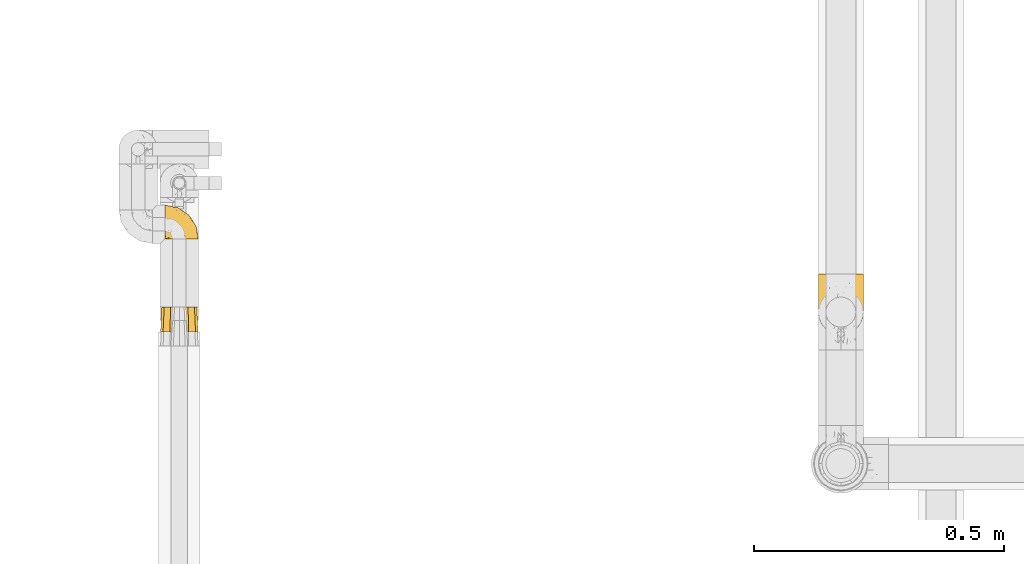
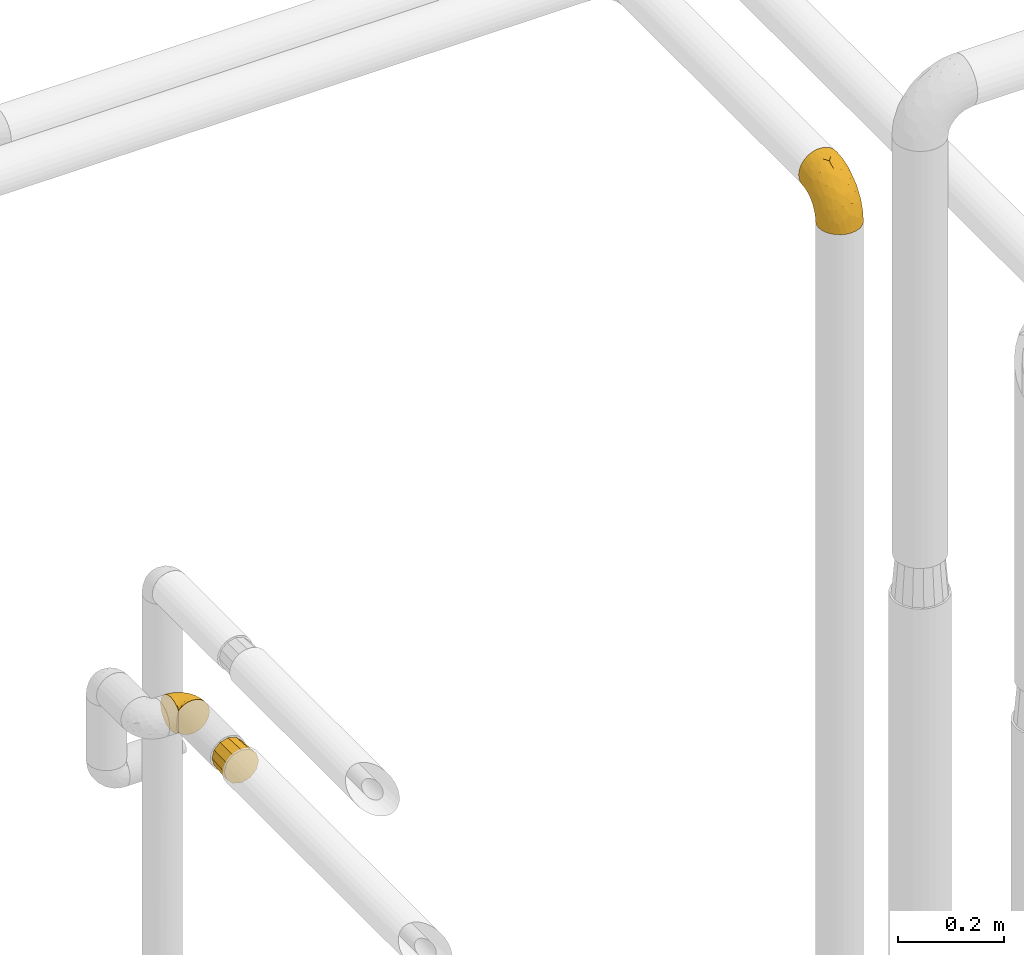
# One storey, part 111 of 827: 3 coverings.
"""IFC2X3 building model written with IfcOpenShell, lengths in millimetres."""

from ifc_helpers import new_model, entity, si_unit, converted_unit, derived_unit, direction, frame, origin, place, context, subcontext, project, spatial, faceted_brep, element, save


model = new_model("IFC2X3")

# Units and contexts
model_context = context("Model", 3, precision=0.01, world=origin(), true_north=direction((6.12303176911189e-17, 1.0)))
body_context = subcontext(model_context, "Body", "Model", "MODEL_VIEW")
ifc_project = project(units=[si_unit("LENGTHUNIT", "METRE", prefix="MILLI"), si_unit("AREAUNIT", "SQUARE_METRE"), si_unit("VOLUMEUNIT", "CUBIC_METRE"), converted_unit("PLANEANGLEUNIT", "DEGREE", entity("IfcRatioMeasure", 0.0174532925199433), si_unit("PLANEANGLEUNIT", "RADIAN"), dimensions=[0, 0, 0, 0, 0, 0, 0]), si_unit("MASSUNIT", "GRAM", prefix="KILO"), derived_unit("MASSDENSITYUNIT", [(si_unit("MASSUNIT", "GRAM", prefix="KILO"), 1), (si_unit("LENGTHUNIT", "METRE"), -3)]), derived_unit("MOMENTOFINERTIAUNIT", [(si_unit("LENGTHUNIT", "METRE"), 4)]), si_unit("TIMEUNIT", "SECOND"), si_unit("FREQUENCYUNIT", "HERTZ"), si_unit("THERMODYNAMICTEMPERATUREUNIT", "DEGREE_CELSIUS"), derived_unit("THERMALTRANSMITTANCEUNIT", [(si_unit("MASSUNIT", "GRAM", prefix="KILO"), 1), (si_unit("THERMODYNAMICTEMPERATUREUNIT", "KELVIN"), -1), (si_unit("TIMEUNIT", "SECOND"), -3)]), derived_unit("VOLUMETRICFLOWRATEUNIT", [(si_unit("LENGTHUNIT", "METRE"), 3), (si_unit("TIMEUNIT", "SECOND"), -1)]), derived_unit("MASSFLOWRATEUNIT", [(si_unit("MASSUNIT", "GRAM", prefix="KILO"), 1), (si_unit("TIMEUNIT", "SECOND"), -1)]), derived_unit("ROTATIONALFREQUENCYUNIT", [(si_unit("TIMEUNIT", "SECOND"), -1)]), si_unit("ELECTRICCURRENTUNIT", "AMPERE"), si_unit("ELECTRICVOLTAGEUNIT", "VOLT"), si_unit("POWERUNIT", "WATT"), si_unit("FORCEUNIT", "NEWTON", prefix="KILO"), si_unit("ILLUMINANCEUNIT", "LUX"), si_unit("LUMINOUSFLUXUNIT", "LUMEN"), si_unit("LUMINOUSINTENSITYUNIT", "CANDELA"), derived_unit("USERDEFINED", [(si_unit("MASSUNIT", "GRAM", prefix="KILO"), -1), (si_unit("LENGTHUNIT", "METRE"), -2), (si_unit("TIMEUNIT", "SECOND"), 3), (si_unit("LUMINOUSFLUXUNIT", "LUMEN"), 1)]), derived_unit("LINEARVELOCITYUNIT", [(si_unit("LENGTHUNIT", "METRE"), 1), (si_unit("TIMEUNIT", "SECOND"), -1)]), si_unit("PRESSUREUNIT", "PASCAL"), derived_unit("USERDEFINED", [(si_unit("LENGTHUNIT", "METRE"), -2), (si_unit("MASSUNIT", "GRAM", prefix="KILO"), 1), (si_unit("TIMEUNIT", "SECOND"), -2)]), derived_unit("LINEARFORCEUNIT", [(si_unit("MASSUNIT", "GRAM", prefix="KILO"), 1), (si_unit("LENGTHUNIT", "METRE"), 1), (si_unit("TIMEUNIT", "SECOND"), -2), (si_unit("LENGTHUNIT", "METRE"), -1)]), derived_unit("PLANARFORCEUNIT", [(si_unit("MASSUNIT", "GRAM", prefix="KILO"), 1), (si_unit("LENGTHUNIT", "METRE"), 1), (si_unit("TIMEUNIT", "SECOND"), -2), (si_unit("LENGTHUNIT", "METRE"), -2)])], contexts=[model_context])

# Site, building, storey
site_placement = place(None, origin())
site = spatial("IfcSite", under=ifc_project, at=site_placement, CompositionType="ELEMENT")
building_placement = place(site_placement, origin())
building = spatial("IfcBuilding", under=site, at=building_placement, CompositionType="ELEMENT")
storey_placement = place(building_placement, frame((0.0, 0.0, 28200.0)))
storey = spatial("IfcBuildingStorey", under=building, at=storey_placement, Name="08", CompositionType="ELEMENT", Elevation=28200.0)

# Coverings
covering_1_placement = place(storey_placement, frame((19745.57, 11707.86, 1518.12)))
element("IfcCovering", 1, at=covering_1_placement, inside=storey, Name=":ADSK_", ObjectType=":ADSK_", PredefinedType="INSULATION", context=body_context, shape_type="Brep", body=[
    faceted_brep([(1.6, 47.38, 74.68), (1.6, 54.67, 70.1), (1.6, 60.76, 64.01), (1.6, 65.34, 56.72), (1.6, 68.18, 48.6), (1.6, 69.15, 40.05), (1.6, 68.18, 31.49), (1.6, 65.33, 23.36), (1.6, 60.75, 16.07), (1.6, 54.66, 9.98), (1.6, 47.37, 5.4), (1.6, 39.25, 2.56), (1.6, 30.7, 1.6), (1.6, 22.59, 2.46), (1.6, 14.86, 5.01), (1.6, 7.84, 9.13), (1.6, 1.85, 14.62), (1.6, 1.85, 16.82), (1.6, 1.85, 18.56), (1.6, 1.85, 20.52), (1.6, 1.85, 22.49), (1.6, 1.85, 24.46), (1.6, 1.85, 26.42), (1.6, 1.85, 28.39), (1.6, 1.85, 30.36), (1.6, 1.85, 32.55), (1.6, 1.85, 34.75), (1.6, 1.85, 36.94), (1.6, 1.85, 39.13), (1.6, 1.85, 41.33), (1.6, 1.85, 43.52), (1.6, 1.85, 45.72), (1.6, 1.85, 47.91), (1.6, 1.85, 50.11), (1.6, 1.85, 52.3), (1.6, 1.85, 54.49), (1.6, 1.85, 56.69), (1.6, 1.85, 58.88), (1.6, 1.85, 61.08), (1.6, 1.85, 63.27), (1.6, 1.85, 65.47), (1.6, 7.85, 70.97), (1.6, 14.88, 75.09), (1.6, 22.61, 77.64), (1.6, 30.7, 78.5), (1.6, 39.26, 77.53), (1.85, 1.6, 14.62), (7.85, 1.6, 9.12), (14.87, 1.6, 5.0), (22.6, 1.6, 2.46), (30.7, 1.6, 1.6), (40.65, 1.6, 2.91), (49.92, 1.6, 6.75), (57.88, 1.6, 12.86), (63.99, 1.6, 20.82), (67.84, 1.6, 30.09), (69.15, 1.6, 40.05), (67.84, 1.6, 50.0), (63.99, 1.6, 59.27), (57.88, 1.6, 67.23), (49.92, 1.6, 73.34), (40.65, 1.6, 77.19), (30.7, 1.6, 78.5), (22.6, 1.6, 77.63), (14.87, 1.6, 75.09), (7.85, 1.6, 70.97), (1.85, 1.6, 65.47), (1.85, 1.6, 63.27), (1.85, 1.6, 62.29), (1.85, 1.6, 60.7), (1.85, 1.6, 59.11), (1.85, 1.6, 57.52), (1.85, 1.6, 55.93), (1.85, 1.6, 54.34), (1.85, 1.6, 52.76), (1.85, 1.6, 51.17), (1.85, 1.6, 49.58), (1.85, 1.6, 47.99), (1.85, 1.6, 46.4), (1.85, 1.6, 44.81), (1.85, 1.6, 43.22), (1.85, 1.6, 41.63), (1.85, 1.6, 40.05), (1.85, 1.6, 38.46), (1.85, 1.6, 36.87), (1.85, 1.6, 35.28), (1.85, 1.6, 33.69), (1.85, 1.6, 32.1), (1.85, 1.6, 30.51), (1.85, 1.6, 28.92), (1.85, 1.6, 27.33), (1.85, 1.6, 25.37), (1.85, 1.6, 23.4), (1.85, 1.6, 21.21), (1.85, 1.6, 19.01), (1.85, 1.6, 16.82), (1.77, 1.78, 42.32), (1.78, 1.77, 44.02), (1.77, 1.78, 47.13), (1.77, 1.77, 48.74), (1.76, 1.79, 23.57), (1.77, 1.78, 25.13), (1.79, 1.76, 61.34), (1.78, 1.77, 22.02), (1.78, 1.77, 29.72), (1.78, 1.76, 56.73), (1.78, 1.77, 55.14), (1.78, 1.77, 37.66), (1.74, 1.8, 64.12), (1.78, 1.76, 28.13), (1.78, 1.77, 26.62), (1.77, 1.78, 31.46), (1.78, 1.77, 16.16), (1.78, 1.77, 39.16), (1.78, 1.76, 50.37), (1.77, 1.77, 17.69), (1.77, 1.78, 19.17), (1.77, 1.77, 62.78), (1.78, 1.77, 58.35), (1.78, 1.77, 45.53), (1.77, 1.78, 59.91), (1.77, 1.77, 65.47), (1.72, 1.8, 65.47), (1.66, 1.82, 65.47), (1.77, 1.77, 14.62), (1.8, 1.72, 14.62), (1.82, 1.66, 14.62), (1.79, 1.76, 20.59), (1.78, 1.77, 32.99), (1.79, 1.76, 34.48), (1.78, 1.77, 51.91), (1.82, 1.66, 65.47), (1.8, 1.72, 65.47), (1.76, 1.78, 53.48), (1.66, 1.82, 14.62), (1.72, 1.8, 14.62), (1.78, 1.77, 40.77), (1.77, 1.78, 35.97), (9.41, 3.72, 7.84), (17.65, 7.41, 3.53), (7.41, 6.13, 8.32), (15.21, 19.34, 2.19), (7.41, 17.64, 3.53), (16.15, 26.8, 1.6), (28.75, 8.87, 1.6), (13.67, 9.2, 4.57), (12.79, 12.79, 3.96), (19.18, 14.62, 2.28), (29.16, 7.34, 1.6), (9.04, 5.33, 7.69), (5.74, 7.7, 8.32), (3.72, 9.41, 7.84), (8.87, 28.75, 1.6), (21.47, 21.47, 1.6), (26.8, 16.15, 1.6), (9.53, 14.14, 4.34), (7.34, 29.16, 1.6), (37.63, 57.02, 29.63), (17.92, 64.92, 27.34), (27.45, 64.0, 40.05), (37.01, 11.92, 2.39), (34.22, 19.16, 2.43), (45.87, 28.65, 9.07), (56.57, 24.62, 16.64), (52.31, 15.19, 9.54), (42.07, 18.36, 4.52), (44.74, 9.2, 4.52), (21.49, 46.98, 7.49), (11.02, 50.24, 7.49), (15.64, 56.1, 12.85), (26.02, 28.97, 2.35), (36.59, 54.46, 22.66), (65.49, 21.34, 32.9), (63.99, 18.4, 25.33), (15.2, 66.44, 40.05), (60.27, 12.07, 16.64), (45.25, 45.49, 19.99), (35.21, 50.57, 16.37), (22.52, 36.04, 3.26), (12.03, 42.07, 3.75), (13.32, 62.12, 19.58), (35.9, 37.37, 7.5), (33.87, 29.39, 4.04), (25.73, 53.59, 13.94), (26.34, 58.06, 19.58), (46.78, 49.27, 28.21), (59.54, 29.63, 24.75), (60.18, 33.21, 31.42), (53.93, 40.1, 26.2), (53.36, 44.08, 33.36), (49.36, 49.36, 40.05), (38.4, 56.68, 40.05), (66.44, 15.2, 40.05), (50.09, 35.57, 16.14), (41.08, 41.7, 12.85), (31.14, 46.4, 10.47), (28.19, 41.41, 6.49), (64.0, 27.45, 40.05), (56.68, 38.4, 40.05), (43.9, 12.99, 75.57), (65.46, 21.33, 47.37), (52.22, 42.89, 52.91), (37.61, 57.04, 50.46), (15.64, 56.11, 67.23), (13.31, 62.13, 60.5), (50.02, 21.89, 70.55), (59.28, 16.62, 63.45), (53.05, 32.9, 62.61), (21.48, 46.99, 72.6), (11.01, 50.25, 72.6), (12.03, 42.08, 76.34), (41.02, 49.91, 59.34), (35.39, 15.6, 77.76), (26.8, 16.15, 78.5), (28.75, 8.87, 78.5), (7.34, 29.16, 78.5), (65.81, 13.16, 53.16), (53.28, 10.83, 70.55), (59.8, 33.8, 48.88), (61.82, 25.02, 54.76), (17.91, 64.92, 52.74), (41.4, 32.83, 71.93), (40.48, 20.56, 75.79), (26.34, 58.07, 60.5), (31.68, 21.46, 77.86), (27.68, 28.1, 77.64), (16.15, 26.8, 78.5), (21.47, 21.47, 78.5), (28.05, 51.29, 67.23), (22.54, 36.04, 76.82), (8.87, 28.75, 78.5), (37.3, 8.45, 77.8), (41.07, 41.73, 67.23), (32.24, 39.27, 73.2), (47.4, 33.56, 67.66), (35.77, 27.29, 75.99), (17.65, 7.41, 76.57), (11.06, 3.51, 73.21), (8.55, 4.68, 71.93), (6.63, 5.52, 71.07), (12.77, 8.75, 75.09), (12.79, 12.79, 76.13), (7.41, 17.65, 76.57), (18.97, 13.9, 77.69), (3.72, 9.42, 72.26), (5.76, 7.68, 71.77), (15.21, 19.33, 77.9), (9.52, 14.13, 75.75)], [[[0, 1, 2, 3, 4, 5, 6, 7, 8, 9, 10, 11, 12, 13, 14, 15, 16, 17, 18, 19, 20, 21, 22, 23, 24, 25, 26, 27, 28, 29, 30, 31, 32, 33, 34, 35, 36, 37, 38, 39, 40, 41, 42, 43, 44, 45]], [[46, 47, 48, 49, 50, 51, 52, 53, 54, 55, 56, 57, 58, 59, 60, 61, 62, 63, 64, 65, 66, 67, 68, 69, 70, 71, 72, 73, 74, 75, 76, 77, 78, 79, 80, 81, 82, 83, 84, 85, 86, 87, 88, 89, 90, 91, 92, 93, 94, 95]], [[96, 97, 30]], [[98, 77, 99]], [[100, 101, 21]], [[69, 68, 102]], [[20, 19, 103]], [[24, 23, 104]], [[20, 103, 100]], [[72, 105, 106]], [[84, 83, 107]], [[89, 88, 104]], [[108, 67, 66]], [[109, 110, 90]], [[111, 25, 24]], [[112, 17, 16]], [[82, 113, 83]], [[109, 23, 22]], [[114, 76, 75]], [[105, 36, 106]], [[104, 111, 24]], [[18, 115, 116]], [[97, 96, 80]], [[67, 108, 117]], [[105, 71, 118]], [[31, 97, 119]], [[102, 120, 69]], [[108, 121, 122, 123, 40]], [[112, 95, 115]], [[17, 115, 18]], [[94, 116, 115]], [[117, 68, 67]], [[38, 117, 39]], [[112, 124, 125, 126, 46]], [[17, 112, 115]], [[70, 120, 118]], [[39, 117, 108]], [[120, 38, 37]], [[120, 37, 118]], [[120, 70, 69]], [[116, 94, 127]], [[128, 86, 129]], [[117, 38, 102]], [[74, 130, 75]], [[99, 33, 32]], [[115, 95, 94]], [[39, 108, 40]], [[108, 66, 131, 132, 121]], [[105, 72, 71]], [[118, 37, 36]], [[71, 70, 118]], [[35, 106, 36]], [[36, 105, 118]], [[35, 133, 106]], [[74, 73, 133]], [[106, 133, 73]], [[99, 114, 33]], [[133, 35, 34]], [[73, 72, 106]], [[95, 112, 46]], [[112, 16, 134, 135, 124]], [[130, 114, 75]], [[99, 76, 114]], [[114, 130, 33]], [[34, 33, 130]], [[78, 77, 98]], [[98, 119, 78]], [[130, 133, 34]], [[133, 130, 74]], [[79, 97, 80]], [[98, 99, 32]], [[98, 32, 31]], [[77, 76, 99]], [[97, 79, 119]], [[136, 96, 29]], [[30, 97, 31]], [[136, 29, 28]], [[81, 80, 96]], [[29, 96, 30]], [[31, 119, 98]], [[119, 79, 78]], [[96, 136, 81]], [[82, 81, 136]], [[113, 107, 83]], [[84, 107, 137]], [[107, 27, 137]], [[113, 28, 107]], [[27, 107, 28]], [[85, 84, 137]], [[137, 27, 26]], [[113, 136, 28]], [[136, 113, 82]], [[109, 89, 104]], [[86, 85, 129]], [[89, 109, 90]], [[111, 87, 128]], [[26, 129, 137]], [[88, 111, 104]], [[25, 111, 128]], [[22, 110, 109]], [[23, 109, 104]], [[110, 91, 90]], [[100, 92, 101]], [[110, 22, 101]], [[91, 110, 101]], [[116, 19, 18]], [[111, 88, 87]], [[127, 103, 19]], [[25, 128, 26]], [[86, 128, 87]], [[128, 129, 26]], [[137, 129, 85]], [[120, 102, 38]], [[117, 102, 68]], [[91, 101, 92]], [[21, 101, 22]], [[93, 92, 103]], [[100, 21, 20]], [[100, 103, 92]], [[127, 93, 103]], [[93, 127, 94]], [[116, 127, 19]], [[126, 138, 47]], [[48, 138, 139]], [[140, 125, 124]], [[141, 142, 143]], [[144, 49, 139]], [[145, 140, 146]], [[48, 139, 49]], [[139, 145, 147]], [[49, 144, 148, 50]], [[126, 125, 149]], [[14, 13, 142]], [[150, 146, 140]], [[149, 140, 145]], [[151, 150, 135]], [[151, 14, 142]], [[16, 15, 134]], [[13, 152, 142]], [[124, 150, 140]], [[141, 143, 153]], [[14, 151, 15]], [[15, 151, 134]], [[47, 46, 126]], [[139, 154, 144]], [[138, 48, 47]], [[125, 140, 149]], [[135, 134, 151]], [[146, 155, 141]], [[145, 146, 147]], [[149, 139, 138]], [[147, 153, 154]], [[147, 146, 141]], [[139, 147, 154]], [[139, 149, 145]], [[149, 138, 126]], [[147, 141, 153]], [[146, 150, 155]], [[151, 155, 150]], [[142, 141, 155]], [[13, 12, 156, 152]], [[152, 143, 142]], [[151, 142, 155]], [[150, 124, 135]], [[157, 158, 159]], [[160, 154, 161]], [[162, 163, 164]], [[165, 166, 160]], [[167, 168, 169]], [[153, 170, 161]], [[156, 12, 11]], [[158, 157, 171]], [[172, 55, 173]], [[158, 6, 174]], [[175, 54, 53]], [[52, 166, 164]], [[52, 164, 53]], [[54, 175, 173]], [[166, 52, 51]], [[176, 177, 171]], [[178, 143, 179]], [[156, 11, 179]], [[8, 7, 180]], [[169, 9, 8]], [[179, 143, 152, 156]], [[179, 11, 10]], [[168, 179, 10]], [[181, 162, 182]], [[179, 167, 178]], [[183, 184, 177]], [[183, 169, 184]], [[176, 171, 185]], [[172, 186, 187]], [[158, 7, 6]], [[159, 158, 174]], [[184, 180, 158]], [[54, 173, 55]], [[180, 169, 8]], [[188, 189, 187]], [[9, 168, 10]], [[186, 188, 187]], [[190, 157, 159, 191]], [[55, 172, 192]], [[176, 193, 194]], [[161, 170, 182]], [[162, 164, 165]], [[175, 164, 163]], [[51, 50, 148]], [[167, 195, 196]], [[178, 182, 170]], [[6, 5, 174]], [[158, 180, 7]], [[169, 180, 184]], [[169, 168, 9]], [[179, 168, 167]], [[182, 162, 165]], [[162, 194, 193]], [[161, 165, 160]], [[195, 181, 196]], [[192, 172, 197]], [[192, 56, 55]], [[189, 190, 198]], [[198, 197, 187]], [[172, 187, 197]], [[185, 189, 188]], [[198, 187, 189]], [[186, 172, 173]], [[173, 163, 186]], [[193, 186, 163]], [[176, 185, 188]], [[185, 157, 190]], [[188, 186, 193]], [[177, 176, 194]], [[188, 193, 176]], [[162, 193, 163]], [[195, 177, 194]], [[171, 177, 184]], [[181, 195, 194]], [[183, 167, 169]], [[162, 181, 194]], [[196, 182, 178]], [[158, 171, 184]], [[171, 157, 185]], [[177, 195, 183]], [[167, 183, 195]], [[182, 196, 181]], [[178, 170, 143]], [[178, 167, 196]], [[164, 175, 53]], [[173, 175, 163]], [[160, 51, 148]], [[164, 166, 165]], [[51, 160, 166]], [[160, 148, 144, 154]], [[153, 161, 154]], [[182, 165, 161]], [[190, 189, 185]], [[143, 170, 153]], [[60, 199, 61]], [[197, 200, 192]], [[201, 190, 202]], [[200, 57, 192]], [[203, 204, 2]], [[205, 206, 207]], [[208, 209, 210]], [[211, 207, 201]], [[212, 213, 214]], [[45, 215, 210]], [[216, 206, 58]], [[45, 44, 215]], [[59, 217, 60]], [[60, 217, 199]], [[0, 45, 210]], [[218, 201, 219]], [[202, 159, 220]], [[205, 221, 222]], [[223, 204, 203]], [[1, 203, 2]], [[57, 200, 216]], [[220, 3, 204]], [[220, 174, 4]], [[1, 0, 209]], [[212, 224, 213]], [[225, 226, 227]], [[228, 223, 203]], [[208, 210, 229]], [[210, 226, 229]], [[3, 220, 4]], [[58, 206, 59]], [[209, 203, 1]], [[202, 220, 223]], [[228, 203, 208]], [[202, 211, 201]], [[3, 2, 204]], [[202, 190, 191, 159]], [[210, 215, 230, 226]], [[199, 212, 231]], [[232, 233, 221]], [[233, 208, 229]], [[207, 206, 219]], [[217, 206, 205]], [[227, 224, 225]], [[233, 232, 228]], [[201, 207, 219]], [[234, 232, 221]], [[218, 219, 200]], [[202, 223, 211]], [[174, 220, 159]], [[174, 5, 4]], [[61, 231, 62]], [[220, 204, 223]], [[210, 209, 0]], [[203, 209, 208]], [[225, 233, 229]], [[224, 227, 213]], [[221, 233, 235]], [[57, 56, 192]], [[198, 218, 197]], [[200, 219, 216]], [[201, 198, 190]], [[197, 218, 200]], [[198, 201, 218]], [[206, 216, 219]], [[58, 57, 216]], [[231, 212, 214]], [[222, 212, 199]], [[228, 211, 223]], [[207, 211, 232]], [[62, 231, 214]], [[199, 231, 61]], [[233, 228, 208]], [[211, 228, 232]], [[222, 221, 235]], [[234, 205, 207]], [[206, 217, 59]], [[199, 217, 205]], [[205, 222, 199]], [[224, 222, 235]], [[222, 224, 212]], [[224, 235, 225]], [[233, 225, 235]], [[226, 225, 229]], [[205, 234, 221]], [[207, 232, 234]], [[63, 214, 236]], [[214, 213, 236]], [[214, 63, 62]], [[237, 236, 238]], [[238, 132, 131]], [[236, 237, 64]], [[239, 240, 241]], [[63, 236, 64]], [[131, 66, 65]], [[237, 131, 65]], [[242, 230, 43]], [[237, 65, 64]], [[239, 121, 132]], [[42, 242, 43]], [[241, 240, 243]], [[41, 123, 244]], [[43, 230, 215, 44]], [[244, 122, 245]], [[227, 246, 243]], [[241, 243, 246]], [[121, 239, 245]], [[41, 40, 123]], [[132, 238, 239]], [[244, 42, 41]], [[131, 237, 238]], [[240, 239, 238]], [[245, 239, 241]], [[247, 241, 246]], [[247, 244, 245]], [[238, 236, 240]], [[243, 236, 213]], [[236, 243, 240]], [[226, 246, 227]], [[243, 213, 227]], [[226, 242, 246]], [[241, 247, 245]], [[246, 242, 247]], [[244, 247, 242]], [[242, 226, 230]], [[42, 244, 242]], [[122, 244, 123]], [[122, 121, 245]]]),
])
covering_2_placement = place(storey_placement, frame((19737.17, 11522.56, 1519.07)))
element("IfcCovering", 2, at=covering_2_placement, inside=storey, Name=":ADSK_", ObjectType=":ADSK_", PredefinedType="INSULATION", context=body_context, shape_type="Brep", body=[
    faceted_brep([(71.75, 51.0, 47.85), (74.1, 51.0, 39.1), (71.75, 51.0, 30.35), (69.41, 51.0, 21.6), (63.0, 51.0, 15.19), (56.6, 51.0, 8.78), (47.85, 51.0, 6.44), (39.1, 51.0, 4.1), (30.35, 51.0, 6.44), (21.6, 51.0, 8.78), (15.19, 51.0, 15.19), (8.78, 51.0, 21.6), (6.44, 51.0, 30.35), (4.1, 51.0, 39.1), (6.44, 51.0, 47.85), (8.78, 51.0, 56.6), (15.19, 51.0, 63.0), (21.6, 51.0, 69.41), (30.35, 51.0, 71.75), (39.1, 51.0, 74.1), (47.85, 51.0, 71.75), (56.6, 51.0, 69.41), (63.0, 51.0, 63.0), (69.41, 51.0, 56.6), (20.35, 0.0, 71.57), (13.48, 0.0, 64.71), (6.62, 0.0, 57.85), (5.04, 0.0, 51.96), (3.32, 0.0, 45.53), (1.6, 0.0, 39.1), (3.32, 0.0, 32.66), (5.04, 0.0, 26.23), (6.62, 0.0, 20.35), (13.48, 0.0, 13.48), (20.35, 0.0, 6.62), (26.23, 0.0, 5.04), (32.66, 0.0, 3.32), (39.1, 0.0, 1.6), (45.53, 0.0, 3.32), (51.96, 0.0, 5.04), (57.85, 0.0, 6.62), (64.71, 0.0, 13.48), (71.57, 0.0, 20.35), (73.15, 0.0, 26.23), (74.87, 0.0, 32.66), (76.6, 0.0, 39.1), (74.87, 0.0, 45.53), (73.15, 0.0, 51.96), (71.57, 0.0, 57.85), (64.71, 0.0, 64.71), (57.85, 0.0, 71.57), (51.96, 0.0, 73.15), (45.53, 0.0, 74.87), (39.1, 0.0, 76.6), (32.66, 0.0, 74.87), (26.23, 0.0, 73.15)], [[[0, 1, 2, 3, 4, 5, 6, 7, 8, 9, 10, 11, 12, 13, 14, 15, 16, 17, 18, 19, 20, 21, 22, 23]], [[24, 25, 26, 27, 28, 29, 30, 31, 32, 33, 34, 35, 36, 37, 38, 39, 40, 41, 42, 43, 44, 45, 46, 47, 48, 49, 50, 51, 52, 53, 54, 55]], [[5, 40, 39, 38, 37, 7, 6]], [[42, 41, 40, 5, 4, 3]], [[45, 44, 43, 42, 3, 2, 1]], [[11, 32, 31, 30, 29, 13, 12]], [[34, 33, 32, 11, 10, 9]], [[37, 36, 35, 34, 9, 8, 7]], [[17, 24, 55, 54, 53, 19, 18]], [[26, 25, 24, 17, 16, 15]], [[29, 28, 27, 26, 15, 14, 13]], [[23, 48, 47, 46, 45, 1, 0]], [[50, 49, 48, 23, 22, 21]], [[53, 52, 51, 50, 21, 20, 19]]]),
])
covering_3_placement = place(storey_placement, frame((21053.31, 11516.12, 2322.4)))
element("IfcCovering", 3, at=covering_3_placement, inside=storey, Name=":ADSK_", ObjectType=":ADSK_", PredefinedType="INSULATION", context=body_context, shape_type="Brep", body=[
    faceted_brep([(90.76, 36.69, 1.6), (87.42, 27.15, 1.6), (82.04, 18.59, 1.6), (74.89, 11.44, 1.6), (66.33, 6.06, 1.6), (56.79, 2.73, 1.6), (46.75, 1.6, 1.6), (36.69, 2.73, 1.6), (27.15, 6.07, 1.6), (18.59, 11.45, 1.6), (11.44, 18.6, 1.6), (6.06, 27.16, 1.6), (2.73, 36.7, 1.6), (1.6, 46.75, 1.6), (2.73, 56.8, 1.6), (6.07, 66.34, 1.6), (11.45, 74.9, 1.6), (18.6, 82.05, 1.6), (27.16, 87.43, 1.6), (36.7, 90.76, 1.6), (46.75, 91.9, 1.6), (56.8, 90.76, 1.6), (66.34, 87.42, 1.6), (74.9, 82.04, 1.6), (82.05, 74.89, 1.6), (87.43, 66.33, 1.6), (90.76, 56.79, 1.6), (91.9, 46.75, 1.6), (35.06, 122.75, 33.98), (24.17, 122.75, 38.49), (14.82, 122.75, 45.67), (7.64, 122.75, 55.02), (3.13, 122.75, 65.91), (1.6, 122.75, 77.6), (3.13, 122.75, 89.28), (7.64, 122.75, 100.17), (14.82, 122.75, 109.52), (24.17, 122.75, 116.7), (35.06, 122.75, 121.21), (46.75, 122.75, 122.75), (58.43, 122.75, 121.21), (69.32, 122.75, 116.7), (78.67, 122.75, 109.52), (85.85, 122.75, 100.17), (90.36, 122.75, 89.28), (91.9, 122.75, 77.6), (90.36, 122.75, 65.91), (85.85, 122.75, 55.02), (78.67, 122.75, 45.67), (69.32, 122.75, 38.49), (58.43, 122.75, 33.98), (46.75, 122.75, 32.45), (46.75, 24.73, 72.81), (55.2, 29.08, 77.17), (46.75, 38.13, 86.21), (46.75, 85.31, 116.82), (54.53, 93.59, 118.49), (46.75, 100.54, 119.23), (59.63, 63.54, 105.14), (62.07, 38.98, 85.37), (71.86, 50.71, 89.33), (62.65, 93.33, 116.14), (71.33, 75.2, 105.06), (72.93, 100.46, 112.15), (91.2, 41.6, 22.95), (86.31, 80.86, 89.91), (80.89, 94.87, 103.39), (79.49, 67.96, 93.6), (90.68, 52.16, 51.41), (86.84, 52.1, 67.71), (87.38, 36.74, 43.53), (76.87, 17.11, 30.91), (83.73, 23.24, 23.58), (81.03, 29.18, 50.07), (91.9, 52.53, 30.68), (91.9, 60.77, 43.01), (91.9, 69.01, 55.34), (91.03, 100.68, 83.48), (87.58, 103.79, 94.96), (56.52, 16.37, 57.29), (46.75, 7.52, 39.03), (60.4, 7.31, 30.66), (91.9, 93.66, 71.81), (91.9, 102.83, 73.63), (91.9, 112.01, 75.46), (67.87, 18.17, 51.57), (90.35, 71.97, 73.13), (69.57, 9.83, 23.16), (46.75, 5.11, 23.8), (79.91, 45.97, 75.6), (91.9, 48.88, 12.33), (91.9, 50.71, 21.51), (74.99, 22.83, 50.46), (46.75, 51.54, 99.61), (91.9, 81.33, 63.57), (88.53, 31.74, 21.26), (72.65, 32.48, 69.54), (46.75, 68.42, 108.21), (62.97, 25.33, 68.42), (46.75, 16.13, 55.92), (66.2, 92.29, 19.36), (56.6, 94.12, 15.76), (59.89, 100.97, 26.13), (90.95, 95.91, 62.78), (90.22, 107.9, 63.65), (76.64, 87.24, 24.34), (71.58, 95.46, 28.46), (79.99, 90.41, 33.53), (89.54, 74.17, 39.46), (89.97, 83.77, 51.05), (81.32, 76.72, 10.94), (74.56, 84.44, 14.55), (84.15, 76.42, 22.21), (90.37, 90.07, 57.05), (87.82, 99.69, 54.0), (90.98, 61.74, 29.19), (90.96, 58.16, 18.85), (85.14, 112.6, 52.84), (58.11, 110.45, 31.47), (46.75, 107.32, 28.31), (78.39, 108.48, 43.0), (88.22, 66.63, 16.9), (66.06, 115.23, 35.98), (68.6, 105.79, 33.91), (63.78, 89.6, 9.97), (88.42, 69.39, 25.93), (90.61, 66.99, 35.61), (83.8, 102.31, 47.45), (77.98, 99.54, 38.26), (91.22, 55.27, 11.7), (83.46, 82.03, 30.13), (46.75, 94.71, 12.12), (46.75, 96.03, 17.02), (84.66, 94.11, 44.39), (86.33, 84.21, 39.83), (46.75, 101.67, 22.67), (46.75, 112.22, 29.63), (15.1, 108.48, 43.0), (9.69, 102.31, 47.45), (15.52, 99.54, 38.26), (8.83, 94.11, 44.38), (35.39, 110.46, 31.47), (12.18, 76.74, 10.93), (1.6, 50.71, 21.51), (2.53, 58.17, 18.84), (2.27, 55.27, 11.7), (36.9, 94.12, 15.76), (27.31, 92.3, 19.36), (33.62, 100.98, 26.14), (5.07, 69.41, 25.94), (9.36, 76.44, 22.21), (5.27, 66.65, 16.9), (27.43, 115.24, 35.98), (1.6, 102.83, 73.63), (1.6, 112.01, 75.46), (10.05, 82.05, 30.12), (16.87, 87.25, 24.33), (8.35, 112.6, 52.84), (3.27, 107.9, 63.65), (1.6, 93.66, 71.81), (21.94, 95.48, 28.45), (29.72, 89.6, 9.97), (1.6, 60.77, 43.01), (1.6, 69.01, 55.34), (3.96, 74.17, 39.46), (1.6, 48.88, 12.33), (18.95, 84.45, 14.54), (2.54, 95.91, 62.78), (3.12, 90.07, 57.05), (1.6, 81.33, 63.57), (2.51, 61.75, 29.2), (3.52, 83.77, 51.05), (7.17, 84.21, 39.81), (1.6, 52.53, 30.68), (13.52, 90.42, 33.52), (2.88, 67.0, 35.61), (5.67, 99.69, 54.0), (24.89, 105.8, 33.91), (12.6, 94.87, 103.39), (7.18, 80.86, 89.91), (14.0, 67.95, 93.6), (22.16, 75.17, 105.05), (21.61, 50.65, 89.27), (3.14, 71.97, 73.13), (6.65, 52.08, 67.67), (20.82, 32.46, 69.49), (31.41, 38.98, 85.36), (5.91, 103.79, 94.96), (2.46, 100.68, 83.48), (33.87, 63.54, 105.14), (30.84, 93.32, 116.13), (38.96, 93.59, 118.49), (20.56, 100.44, 112.15), (2.81, 52.17, 51.41), (6.1, 36.75, 43.51), (2.29, 41.61, 22.95), (33.08, 7.31, 30.66), (16.61, 17.12, 30.91), (36.96, 16.37, 57.3), (9.75, 23.26, 23.58), (25.61, 18.17, 51.56), (30.5, 25.33, 68.41), (23.91, 9.84, 23.16), (12.45, 29.19, 50.07), (18.49, 22.84, 50.45), (4.96, 31.75, 21.25), (13.56, 45.96, 75.56), (38.28, 29.07, 77.16)], [[[0, 1, 2, 3, 4, 5, 6, 7, 8, 9, 10, 11, 12, 13, 14, 15, 16, 17, 18, 19, 20, 21, 22, 23, 24, 25, 26, 27]], [[28, 29, 30, 31, 32, 33, 34, 35, 36, 37, 38, 39, 40, 41, 42, 43, 44, 45, 46, 47, 48, 49, 50, 51]], [[52, 53, 54]], [[55, 56, 57]], [[58, 59, 60]], [[61, 62, 63]], [[27, 64, 0]], [[65, 66, 67]], [[41, 40, 61]], [[68, 69, 70]], [[66, 43, 42]], [[63, 42, 41]], [[71, 72, 73]], [[72, 2, 1]], [[68, 74, 75, 76]], [[45, 44, 77]], [[43, 78, 44]], [[79, 80, 81]], [[77, 82, 83, 84, 45]], [[79, 81, 85]], [[71, 2, 72]], [[65, 86, 77]], [[4, 81, 5]], [[66, 65, 78]], [[4, 3, 87]], [[81, 88, 5]], [[63, 66, 42]], [[68, 70, 64]], [[67, 60, 89]], [[71, 3, 2]], [[64, 27, 90, 91, 74]], [[92, 71, 73]], [[40, 57, 56]], [[59, 93, 54]], [[86, 76, 94, 82]], [[1, 0, 95]], [[58, 62, 61]], [[60, 96, 89]], [[85, 81, 87]], [[56, 97, 58]], [[65, 67, 69]], [[87, 81, 4]], [[67, 89, 69]], [[61, 63, 41]], [[95, 72, 1]], [[73, 72, 70]], [[69, 73, 70]], [[73, 89, 96]], [[3, 71, 87]], [[85, 87, 71]], [[58, 61, 56]], [[59, 58, 93]], [[76, 86, 68]], [[69, 89, 73]], [[68, 86, 69]], [[65, 69, 86]], [[68, 64, 74]], [[95, 64, 70]], [[98, 79, 85]], [[79, 52, 99, 80]], [[66, 62, 67]], [[62, 58, 60]], [[62, 60, 67]], [[59, 98, 96]], [[59, 96, 60]], [[96, 85, 92]], [[88, 81, 80]], [[88, 6, 5]], [[66, 63, 62]], [[64, 95, 0]], [[72, 95, 70]], [[77, 44, 78]], [[86, 82, 77]], [[40, 39, 57]], [[96, 98, 85]], [[40, 56, 61]], [[66, 78, 43]], [[77, 78, 65]], [[79, 98, 53]], [[96, 92, 73]], [[85, 71, 92]], [[97, 56, 55]], [[97, 93, 58]], [[53, 98, 59]], [[54, 53, 59]], [[79, 53, 52]], [[100, 101, 102]], [[46, 45, 84, 83]], [[103, 104, 82]], [[82, 104, 83]], [[105, 106, 107]], [[108, 109, 76]], [[110, 111, 112]], [[103, 113, 114]], [[115, 74, 116]], [[48, 47, 117]], [[118, 102, 119]], [[49, 48, 120]], [[74, 91, 116]], [[116, 121, 115]], [[49, 122, 50]], [[123, 106, 102]], [[124, 111, 22]], [[125, 126, 115]], [[23, 22, 111]], [[24, 110, 121]], [[120, 127, 128]], [[90, 26, 129]], [[27, 26, 90]], [[121, 125, 115]], [[24, 121, 25]], [[130, 105, 107]], [[129, 25, 116]], [[21, 20, 131]], [[120, 123, 122]], [[112, 105, 130]], [[50, 118, 51]], [[21, 124, 22]], [[101, 131, 132]], [[117, 120, 48]], [[24, 23, 110]], [[127, 114, 133]], [[75, 108, 76]], [[107, 134, 130]], [[133, 114, 113]], [[129, 116, 91]], [[25, 121, 116]], [[121, 112, 125]], [[75, 74, 115]], [[101, 135, 102]], [[131, 101, 21]], [[101, 100, 124]], [[128, 127, 133]], [[119, 136, 51, 118]], [[104, 47, 46]], [[83, 104, 46]], [[117, 104, 114]], [[101, 124, 21]], [[111, 124, 100]], [[102, 118, 123]], [[133, 134, 107]], [[111, 110, 23]], [[114, 104, 103]], [[94, 76, 109]], [[121, 110, 112]], [[122, 118, 50]], [[134, 109, 108]], [[133, 107, 128]], [[112, 108, 125]], [[126, 125, 108]], [[108, 75, 126]], [[75, 115, 126]], [[109, 134, 133]], [[130, 108, 112]], [[108, 130, 134]], [[105, 112, 111]], [[111, 100, 105]], [[106, 105, 100]], [[102, 106, 100]], [[128, 106, 123]], [[90, 129, 91]], [[25, 129, 26]], [[104, 117, 47]], [[117, 114, 127]], [[82, 94, 103]], [[113, 94, 109]], [[94, 113, 103]], [[133, 113, 109]], [[106, 128, 107]], [[123, 120, 128]], [[120, 122, 49]], [[118, 122, 123]], [[135, 101, 132]], [[135, 119, 102]], [[117, 127, 120]], [[30, 29, 137]], [[138, 139, 140]], [[51, 136, 119, 141]], [[142, 17, 16]], [[143, 144, 145]], [[146, 147, 148]], [[149, 150, 151]], [[152, 29, 28]], [[33, 32, 153, 154]], [[150, 155, 156]], [[157, 31, 30]], [[153, 158, 159]], [[29, 152, 137]], [[148, 141, 119]], [[156, 160, 147]], [[148, 135, 146]], [[137, 138, 157]], [[19, 161, 146]], [[162, 163, 164]], [[14, 13, 165]], [[153, 32, 158]], [[147, 161, 166]], [[18, 17, 166]], [[167, 168, 169]], [[166, 150, 156]], [[151, 150, 142]], [[151, 170, 149]], [[151, 16, 15]], [[171, 140, 172]], [[165, 143, 145]], [[173, 170, 144]], [[142, 166, 17]], [[19, 131, 20]], [[144, 170, 151]], [[18, 161, 19]], [[173, 144, 143]], [[140, 139, 174]], [[171, 164, 163]], [[164, 172, 155]], [[151, 15, 144]], [[145, 15, 14]], [[173, 162, 170]], [[149, 175, 164]], [[19, 146, 131]], [[132, 131, 146]], [[160, 148, 147]], [[159, 158, 167]], [[135, 132, 146]], [[158, 32, 31]], [[157, 158, 31]], [[167, 158, 176]], [[166, 161, 18]], [[146, 161, 147]], [[148, 177, 141]], [[171, 168, 140]], [[171, 163, 169]], [[151, 142, 16]], [[166, 142, 150]], [[152, 141, 177]], [[51, 141, 28]], [[138, 140, 176]], [[172, 140, 174]], [[175, 149, 170]], [[164, 150, 149]], [[170, 162, 175]], [[162, 164, 175]], [[155, 172, 174]], [[171, 172, 164]], [[155, 174, 156]], [[164, 155, 150]], [[160, 156, 174]], [[147, 166, 156]], [[139, 160, 174]], [[148, 160, 177]], [[15, 145, 144]], [[165, 145, 14]], [[137, 157, 30]], [[158, 157, 176]], [[168, 167, 176]], [[169, 159, 167]], [[140, 168, 176]], [[169, 168, 171]], [[137, 177, 139]], [[160, 139, 177]], [[141, 152, 28]], [[137, 152, 177]], [[148, 119, 135]], [[157, 138, 176]], [[139, 138, 137]], [[178, 179, 180]], [[181, 180, 182]], [[179, 183, 184]], [[185, 186, 182]], [[187, 188, 179]], [[188, 33, 154, 153, 159]], [[181, 189, 190]], [[35, 34, 187]], [[191, 38, 190]], [[192, 178, 181]], [[179, 184, 180]], [[192, 190, 37]], [[37, 190, 38]], [[36, 35, 178]], [[54, 93, 186]], [[35, 187, 178]], [[193, 194, 184]], [[195, 173, 143, 165, 13]], [[195, 193, 173]], [[193, 163, 162, 173]], [[13, 12, 195]], [[8, 7, 196]], [[9, 197, 10]], [[198, 80, 99, 52]], [[196, 7, 88]], [[197, 199, 10]], [[182, 189, 181]], [[200, 198, 201]], [[200, 196, 198]], [[9, 8, 202]], [[194, 199, 203]], [[192, 37, 36]], [[80, 196, 88]], [[183, 159, 169, 163]], [[188, 34, 33]], [[202, 200, 197]], [[185, 203, 204]], [[202, 8, 196]], [[10, 199, 11]], [[12, 11, 205]], [[38, 191, 57]], [[189, 97, 191]], [[203, 199, 197]], [[205, 199, 194]], [[204, 203, 197]], [[184, 203, 206]], [[200, 202, 196]], [[197, 9, 202]], [[207, 54, 186]], [[97, 55, 191]], [[194, 203, 184]], [[183, 163, 193]], [[184, 206, 180]], [[183, 193, 184]], [[205, 195, 12]], [[193, 195, 194]], [[80, 198, 196]], [[207, 186, 201]], [[182, 180, 206]], [[181, 178, 180]], [[185, 182, 206]], [[182, 186, 189]], [[203, 185, 206]], [[185, 200, 201]], [[7, 6, 88]], [[178, 192, 36]], [[190, 192, 181]], [[199, 205, 11]], [[195, 205, 194]], [[159, 183, 188]], [[179, 188, 183]], [[57, 191, 55]], [[57, 39, 38]], [[189, 191, 190]], [[188, 187, 34]], [[178, 187, 179]], [[186, 93, 189]], [[197, 200, 204]], [[185, 204, 200]], [[189, 93, 97]], [[207, 198, 52]], [[185, 201, 186]], [[198, 207, 201]], [[54, 207, 52]]]),
])

save(model, "model.ifc")
